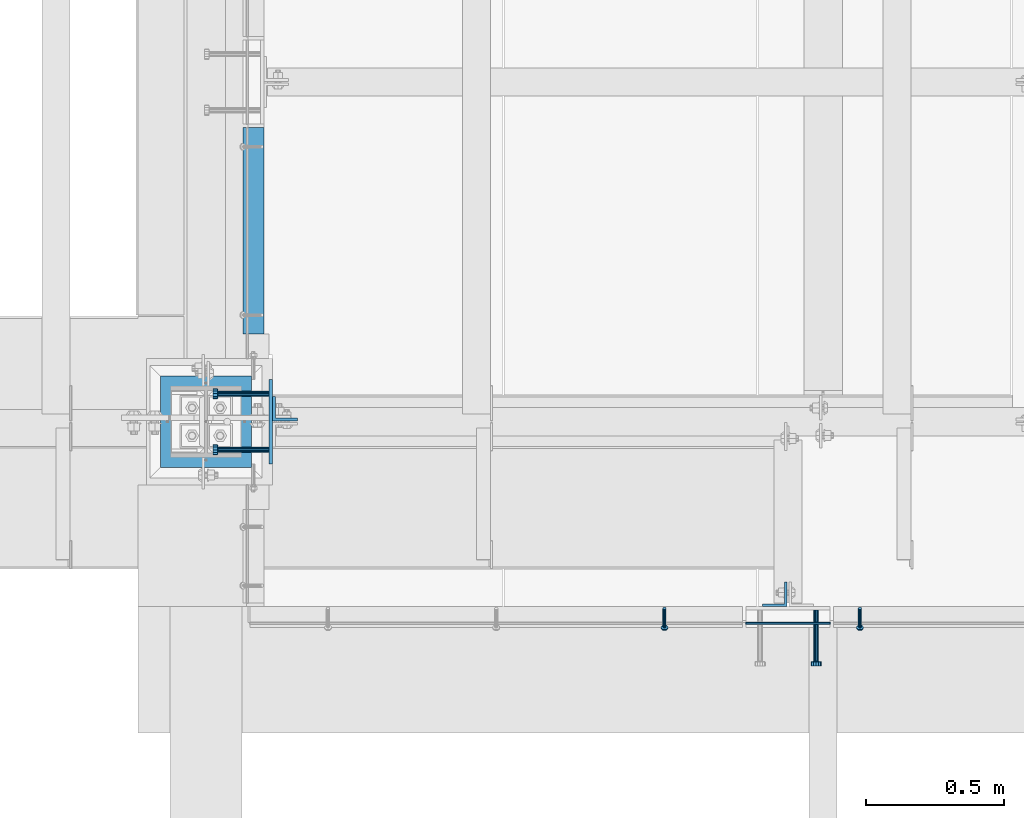
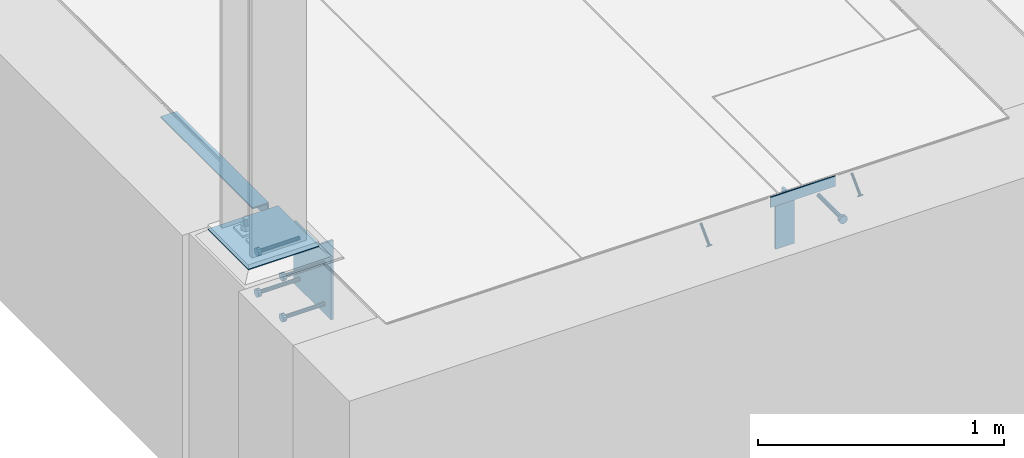
# One storey, part 2045 of 3843: 11 beams, 2 members, 8 elements without a shape of their own.
"""IFC2X3 building model written with IfcOpenShell, lengths in millimetres."""

from ifc_helpers import new_model, si_unit, frame, origin_with_axes, place, context, subcontext, project, spatial, faceted_brep, material, type_object, element, aggregate, save


model = new_model("IFC2X3")

# Units and contexts
model_context = context("Model", 3, precision=1e-05, world=origin_with_axes())
body_context = subcontext(model_context, "Body", "Model", "MODEL_VIEW")
ifc_project = project(units=[si_unit("LENGTHUNIT", "METRE", prefix="MILLI"), si_unit("AREAUNIT", "SQUARE_METRE"), si_unit("VOLUMEUNIT", "CUBIC_METRE"), si_unit("MASSUNIT", "GRAM", prefix="KILO"), si_unit("TIMEUNIT", "SECOND"), si_unit("PLANEANGLEUNIT", "RADIAN"), si_unit("SOLIDANGLEUNIT", "STERADIAN"), si_unit("THERMODYNAMICTEMPERATUREUNIT", "DEGREE_CELSIUS"), si_unit("LUMINOUSINTENSITYUNIT", "LUMEN")], contexts=[model_context])

# Site, building, storey
site_placement = place(None, origin_with_axes())
site = spatial("IfcSite", under=ifc_project, at=site_placement, CompositionType="ELEMENT")
building_placement = place(site_placement, origin_with_axes())
building = spatial("IfcBuilding", under=site, at=building_placement, Name="Undefined", CompositionType="ELEMENT")
storey_placement = place(building_placement, origin_with_axes())
storey = spatial("IfcBuildingStorey", under=building, at=storey_placement, Name="Undefined", CompositionType="ELEMENT", Elevation=0.0)

# Assembly, beam
assembly_1_placement = place(storey_placement, origin_with_axes())
assembly_1 = element("IfcElementAssembly", 1, at=assembly_1_placement, inside=storey, Name="EMBED PLATE", AssemblyPlace="NOTDEFINED", PredefinedType="RIGID_FRAME")
ifc_material_1 = material(Name="STEEL/A36")
beam_type_1 = type_object("IfcBeamType", PredefinedType="NOTDEFINED")
beam_1_placement = place(assembly_1_placement, frame((58191.4, 14268.45, 30454.6), z_axis=(0.0, 0.0, 1.0), x_axis=(-1.0, 0.0, 0.0)))
beam_1 = element("IfcBeam", 2, at=beam_1_placement, type_object=beam_type_1, material=ifc_material_1, Name="PLATE", context=body_context, shape_type="Brep", body=[
    faceted_brep([(0.0, 3.17499999999927, -25.4000000000015), (0.0, 3.17499999999927, 25.4000000000015), (304.800000000003, 3.17500000000291, 25.4000000000015), (304.800000000003, 3.17500000000291, -25.4000000000015), (0.0, -3.17499999999927, 25.4000000000015), (304.800000000003, -3.17500000000291, 25.4000000000015), (0.0, -3.17499999999927, -25.4000000000015), (304.800000000003, -3.17500000000291, -25.4000000000015)], [[[0, 1, 2, 3]], [[1, 4, 5, 2]], [[4, 6, 7, 5]], [[6, 0, 3, 7]], [[5, 7, 3, 2]], [[6, 4, 1, 0]]]),
])

# Assembly, member
assembly_2_placement = place(storey_placement, origin_with_axes())
assembly_2 = element("IfcElementAssembly", 3, at=assembly_2_placement, inside=storey, Name="ANGLE", AssemblyPlace="NOTDEFINED", PredefinedType="RIGID_FRAME")
ifc_material_2 = material(Name="STEEL/A108")
member_type = type_object("IfcMemberType", PredefinedType="NOTDEFINED")
member_1_placement = place(assembly_2_placement, frame((58299.3500082383, 14322.4244471697, 30422.8500024177), z_axis=(1.0, 0.0, 0.0), x_axis=(0.0, -0.707106781186548, -0.707106781186548)))
member_1 = element("IfcMember", 4, at=member_1_placement, type_object=member_type, material=ifc_material_2, Name="HEADED STUD ANCHOR", context=body_context, shape_type="Brep", body=[
    faceted_brep([(7.27595761418343e-12, -3.18000006675175, 5.5), (0.0, -5.49999999998363, 3.1800000667572), (94.4879985803855, -5.50000000011278, 3.1800000667572), (94.4879985803782, -3.18000006687362, 5.5), (0.0, -6.3499999046162, 0.0), (94.4879985803855, -6.34999990474535, 0.0), (0.0, -5.49999999998363, -3.1800000667572), (94.4879985803855, -5.50000000011278, -3.1800000667572), (7.27595761418343e-12, -3.18000006675175, -5.5), (94.4879985803782, -3.18000006687362, -5.5), (7.27595761418343e-12, -1.81898940354586e-12, -6.34999990463257), (94.4879985803782, -1.20053300634027e-10, -6.34999990463257), (0.0, 3.18000006675175, -5.5), (94.4879985803709, 3.18000006663351, -5.5), (7.27595761418343e-12, 5.49999999998363, -3.1800000667572), (94.4879985803709, 5.49999999987267, -3.1800000667572), (7.27595761418343e-12, 6.3499999046162, 0.0), (94.4879985803673, 6.34999990450706, 0.0), (7.27595761418343e-12, 5.49999999998363, 3.1800000667572), (94.4879985803709, 5.49999999987267, 3.1800000667572), (0.0, 3.18000006675175, 5.5), (94.4879985803709, 3.18000006663351, 5.5), (7.27595761418343e-12, -1.81898940354586e-12, 6.34999990463257), (94.4879985803782, -1.20053300634027e-10, 6.34999990463257), (96.5199985498621, -10.9899997712273, 6.34999990463257), (96.5199985498548, -6.34000015270249, 10.9899997711182), (96.5199985498621, -12.6999998093743, 0.0), (96.5199985498621, -10.9899997712273, -6.34999990463257), (96.5199985498548, -6.34000015270249, -10.9899997711182), (96.5199985498475, -1.21872290037572e-10, -12.6899995803833), (96.5199985498402, 6.34000015245874, -10.9899997711182), (96.519998549833, 10.9899997709817, -6.34999990463257), (96.519998549833, 12.6999998091305, 0.0), (96.519998549833, 10.9899997709817, 6.34999990463257), (96.5199985498402, 6.34000015245874, 10.9899997711182), (96.5199985498475, -1.21872290037572e-10, 12.6899995803833), (101.599998473539, -10.9899997712328, 6.34999990463257), (101.599998473532, -6.34000015270976, 10.9899997711182), (101.599998473539, -12.6999998093797, 0.0), (101.599998473539, -10.9899997712328, -6.34999990463257), (101.599998473532, -6.34000015270976, -10.9899997711182), (101.599998473524, -1.29148247651756e-10, -12.6899995803833), (101.599998473517, 6.34000015245329, -10.9899997711182), (101.59999847351, 10.9899997709763, -6.34999990463257), (101.599998473503, 12.6999998091196, 0.0), (101.59999847351, 10.9899997709763, 6.34999990463257), (101.599998473517, 6.34000015245329, 10.9899997711182), (101.599998473524, -1.29148247651756e-10, 12.6899995803833)], [[[0, 1, 2, 3]], [[1, 4, 5, 2]], [[4, 6, 7, 5]], [[6, 8, 9, 7]], [[8, 10, 11, 9]], [[10, 12, 13, 11]], [[12, 14, 15, 13]], [[14, 16, 17, 15]], [[16, 18, 19, 17]], [[18, 20, 21, 19]], [[20, 22, 23, 21]], [[22, 0, 3, 23]], [[22, 20, 18, 16, 14, 12, 10, 8, 6, 4, 1, 0]], [[3, 2, 24, 25]], [[2, 5, 26, 24]], [[5, 7, 27, 26]], [[7, 9, 28, 27]], [[9, 11, 29, 28]], [[11, 13, 30, 29]], [[13, 15, 31, 30]], [[15, 17, 32, 31]], [[17, 19, 33, 32]], [[19, 21, 34, 33]], [[21, 23, 35, 34]], [[23, 3, 25, 35]], [[25, 24, 36, 37]], [[24, 26, 38, 36]], [[26, 27, 39, 38]], [[27, 28, 40, 39]], [[28, 29, 41, 40]], [[29, 30, 42, 41]], [[30, 31, 43, 42]], [[31, 32, 44, 43]], [[32, 33, 45, 44]], [[33, 34, 46, 45]], [[34, 35, 47, 46]], [[35, 25, 37, 47]], [[38, 39, 40, 41, 42, 43, 44, 45, 46, 47, 37, 36]]]),
])
aggregate(assembly_2, [member_1])

assembly_3_placement = place(storey_placement, origin_with_axes())
assembly_3 = element("IfcElementAssembly", 5, at=assembly_3_placement, inside=storey, Name="ANGLE", AssemblyPlace="NOTDEFINED", PredefinedType="RIGID_FRAME")
member_2_placement = place(assembly_3_placement, frame((57591.324996253, 14322.4243726418, 30422.8500024177), z_axis=(1.0, 0.0, 0.0), x_axis=(0.0, -0.707106781186548, -0.707106781186548)))
member_2 = element("IfcMember", 6, at=member_2_placement, type_object=member_type, material=ifc_material_2, Name="HEADED STUD ANCHOR", context=body_context, shape_type="Brep", body=[
    faceted_brep([(7.27595761418343e-12, -3.18000006675175, 5.5), (0.0, -5.49999999998363, 3.1800000667572), (94.4879985803855, -5.50000000011278, 3.1800000667572), (94.4879985803782, -3.18000006687362, 5.5), (0.0, -6.3499999046162, 0.0), (94.4879985803855, -6.34999990474535, 0.0), (0.0, -5.49999999998363, -3.1800000667572), (94.4879985803855, -5.50000000011278, -3.1800000667572), (7.27595761418343e-12, -3.18000006675175, -5.5), (94.4879985803782, -3.18000006687362, -5.5), (7.27595761418343e-12, -1.81898940354586e-12, -6.34999990463257), (94.4879985803782, -1.20053300634027e-10, -6.34999990463257), (0.0, 3.18000006675175, -5.5), (94.4879985803709, 3.18000006663351, -5.5), (7.27595761418343e-12, 5.49999999998363, -3.1800000667572), (94.4879985803709, 5.49999999987267, -3.1800000667572), (7.27595761418343e-12, 6.3499999046162, 0.0), (94.4879985803673, 6.34999990450706, 0.0), (7.27595761418343e-12, 5.49999999998363, 3.1800000667572), (94.4879985803709, 5.49999999987267, 3.1800000667572), (0.0, 3.18000006675175, 5.5), (94.4879985803709, 3.18000006663351, 5.5), (7.27595761418343e-12, -1.81898940354586e-12, 6.34999990463257), (94.4879985803782, -1.20053300634027e-10, 6.34999990463257), (96.5199985498621, -10.9899997712273, 6.34999990463257), (96.5199985498548, -6.34000015270249, 10.9899997711182), (96.5199985498621, -12.6999998093743, 0.0), (96.5199985498621, -10.9899997712273, -6.34999990463257), (96.5199985498548, -6.34000015270249, -10.9899997711182), (96.5199985498475, -1.21872290037572e-10, -12.6899995803833), (96.5199985498402, 6.34000015245874, -10.9899997711182), (96.519998549833, 10.9899997709817, -6.34999990463257), (96.519998549833, 12.6999998091305, 0.0), (96.519998549833, 10.9899997709817, 6.34999990463257), (96.5199985498402, 6.34000015245874, 10.9899997711182), (96.5199985498475, -1.21872290037572e-10, 12.6899995803833), (101.599998473539, -10.9899997712328, 6.34999990463257), (101.599998473532, -6.34000015270976, 10.9899997711182), (101.599998473539, -12.6999998093797, 0.0), (101.599998473539, -10.9899997712328, -6.34999990463257), (101.599998473532, -6.34000015270976, -10.9899997711182), (101.599998473524, -1.29148247651756e-10, -12.6899995803833), (101.599998473517, 6.34000015245329, -10.9899997711182), (101.59999847351, 10.9899997709763, -6.34999990463257), (101.599998473503, 12.6999998091196, 0.0), (101.59999847351, 10.9899997709763, 6.34999990463257), (101.599998473517, 6.34000015245329, 10.9899997711182), (101.599998473524, -1.29148247651756e-10, 12.6899995803833)], [[[0, 1, 2, 3]], [[1, 4, 5, 2]], [[4, 6, 7, 5]], [[6, 8, 9, 7]], [[8, 10, 11, 9]], [[10, 12, 13, 11]], [[12, 14, 15, 13]], [[14, 16, 17, 15]], [[16, 18, 19, 17]], [[18, 20, 21, 19]], [[20, 22, 23, 21]], [[22, 0, 3, 23]], [[22, 20, 18, 16, 14, 12, 10, 8, 6, 4, 1, 0]], [[3, 2, 24, 25]], [[2, 5, 26, 24]], [[5, 7, 27, 26]], [[7, 9, 28, 27]], [[9, 11, 29, 28]], [[11, 13, 30, 29]], [[13, 15, 31, 30]], [[15, 17, 32, 31]], [[17, 19, 33, 32]], [[19, 21, 34, 33]], [[21, 23, 35, 34]], [[23, 3, 25, 35]], [[25, 24, 36, 37]], [[24, 26, 38, 36]], [[26, 27, 39, 38]], [[27, 28, 40, 39]], [[28, 29, 41, 40]], [[29, 30, 42, 41]], [[30, 31, 43, 42]], [[31, 32, 44, 43]], [[32, 33, 45, 44]], [[33, 34, 46, 45]], [[34, 35, 47, 46]], [[35, 25, 37, 47]], [[38, 39, 40, 41, 42, 43, 44, 45, 46, 47, 37, 36]]]),
])
aggregate(assembly_3, [member_2])

# Assembly, beam
assembly_4_placement = place(storey_placement, origin_with_axes())
assembly_4 = element("IfcElementAssembly", 7, at=assembly_4_placement, inside=storey, Name="EMBED PLATE", AssemblyPlace="NOTDEFINED", PredefinedType="RIGID_FRAME")
beam_type_2 = type_object("IfcBeamType", PredefinedType="NOTDEFINED")
beam_2_placement = place(assembly_4_placement, frame((56165.75, 14998.7, 30429.2), z_axis=(0.0, 1.0, 0.0), x_axis=(0.0, 0.0, -1.0)))
beam_2 = element("IfcBeam", 8, at=beam_2_placement, type_object=beam_type_2, material=ifc_material_1, Name="EMBED PLATE", context=body_context, shape_type="Brep", body=[
    faceted_brep([(-1.0550138540566e-10, 6.34999999999854, -152.400000000664), (1.0550138540566e-10, 6.34999999999854, 152.400000000656), (304.799999999999, 6.34999999999854, 152.400000000001), (304.799999999999, 6.34999999999854, -152.400000000001), (1.0550138540566e-10, -6.34999999999854, 152.400000000656), (304.799999999999, -6.34999999999854, 152.400000000001), (-1.0550138540566e-10, -6.34999999999854, -152.400000000664), (304.799999999999, -6.34999999999854, -152.400000000001)], [[[0, 1, 2, 3]], [[1, 4, 5, 2]], [[4, 6, 7, 5]], [[6, 0, 3, 7]], [[5, 7, 3, 2]], [[6, 4, 1, 0]]]),
])

assembly_5_placement = place(storey_placement, origin_with_axes())
assembly_5 = element("IfcElementAssembly", 9, at=assembly_5_placement, inside=storey, Name="ANGLE", AssemblyPlace="NOTDEFINED", PredefinedType="RIGID_FRAME")
beam_type_3 = type_object("IfcBeamType", Name="L3X3X1/4", PredefinedType="NOTDEFINED")
beam_3_placement = place(assembly_5_placement, frame((56102.2499885878, 15316.2000002665, 30391.1000045777), z_axis=(0.0, 0.0, -1.0), x_axis=(0.0, 1.0, 0.0)))
beam_3 = element("IfcBeam", 10, at=beam_3_placement, type_object=beam_type_3, material=ifc_material_1, Name="ANGLE", ObjectType="L3X3X1/4", context=body_context, shape_type="Brep", body=[
    faceted_brep([(0.0, 38.0999999999985, -38.0999999999985), (0.0, 38.0999999999985, 38.0999999999985), (747.71198334926, 38.0999999996129, 38.0999999999985), (747.71198334926, 38.0999999996129, -38.0999999999985), (0.0, 31.75, 38.0999999999985), (747.711983349258, 31.7499999996144, 38.0999999999985), (0.0, 31.75, -31.75), (747.711983349258, 31.7499999996144, -31.75), (0.0, -38.0999999999985, -31.75), (747.711983349222, -38.1000000003842, -31.75), (0.0, -38.0999999999985, -38.0999999999985), (747.711983349222, -38.1000000003842, -38.0999999999985)], [[[0, 1, 2, 3]], [[1, 4, 5, 2]], [[4, 6, 7, 5]], [[6, 8, 9, 7]], [[8, 10, 11, 9]], [[10, 0, 3, 11]], [[5, 7, 9, 11, 3, 2]], [[10, 8, 6, 4, 1, 0]]]),
])
aggregate(assembly_5, [beam_3])

assembly_6_placement = place(storey_placement, origin_with_axes())
assembly_6 = element("IfcElementAssembly", 11, at=assembly_6_placement, inside=storey, Name="BEAM", AssemblyPlace="NOTDEFINED", PredefinedType="RIGID_FRAME")
beam_type_4 = type_object("IfcBeamType", Name="L3-1/2X3-1/2X3/8", PredefinedType="NOTDEFINED")
beam_4_placement = place(assembly_6_placement, frame((56216.55, 15046.325, 30391.1), z_axis=(0.0, 1.0, 0.0), x_axis=(0.0, 0.0, -1.0)))
beam_4 = element("IfcBeam", 12, at=beam_4_placement, type_object=beam_type_4, material=ifc_material_1, Name="ANGLE", ObjectType="L3-1/2X3-1/2X3/8", context=body_context, shape_type="Brep", body=[
    faceted_brep([(-3.63797880709171e-12, 44.4499999999971, -44.4500000000007), (-3.63797880709171e-12, 44.4499999999971, 44.4500000000007), (228.600000000006, 44.4499999999971, 44.4500000000007), (228.600000000006, 44.4499999999971, -44.4500000000007), (0.0, 34.9250000000029, 44.4500000000007), (228.600000000006, 34.9250000000029, 44.4500000000007), (0.0, 34.9250000000029, -34.9250000000029), (228.600000000006, 34.9250000000029, -34.9249999999993), (0.0, -44.4499999999971, -34.9249999999993), (228.600000000006, -44.4499999999971, -34.9249999999993), (3.63797880709171e-12, -44.4499999999971, -44.4500000000007), (228.600000000006, -44.4499999999971, -44.4500000000007)], [[[0, 1, 2, 3]], [[1, 4, 5, 2]], [[4, 6, 7, 5]], [[6, 8, 9, 7]], [[8, 10, 11, 9]], [[10, 0, 3, 11]], [[5, 7, 9, 11, 3, 2]], [[10, 8, 6, 4, 1, 0]]]),
])
aggregate(assembly_6, [beam_4])

assembly_7_placement = place(storey_placement, origin_with_axes())
assembly_7 = element("IfcElementAssembly", 13, at=assembly_7_placement, inside=storey, Name="BEAM", AssemblyPlace="NOTDEFINED", PredefinedType="RIGID_FRAME")
beam_5_placement = place(assembly_7_placement, frame((57991.375, 14373.225, 30391.1), z_axis=(-1.0, 0.0, 0.0), x_axis=(0.0, 0.0, -1.0)))
beam_5 = element("IfcBeam", 14, at=beam_5_placement, type_object=beam_type_4, material=ifc_material_1, Name="ANGLE", ObjectType="L3-1/2X3-1/2X3/8", context=body_context, shape_type="Brep", body=[
    faceted_brep([(-3.63797880709171e-12, 44.4499999999971, -44.4500000000007), (-3.63797880709171e-12, 44.4499999999971, 44.4500000000007), (228.600000000006, 44.4499999999971, 44.4500000000007), (228.600000000006, 44.4499999999971, -44.4500000000007), (0.0, 34.9250000000029, 44.4500000000007), (228.600000000006, 34.9250000000029, 44.4500000000007), (0.0, 34.9250000000029, -34.9250000000029), (228.600000000006, 34.9250000000029, -34.9249999999993), (0.0, -44.4499999999971, -34.9249999999993), (228.600000000006, -44.4499999999971, -34.9249999999993), (3.63797880709171e-12, -44.4499999999971, -44.4500000000007), (228.600000000006, -44.4499999999971, -44.4500000000007)], [[[0, 1, 2, 3]], [[1, 4, 5, 2]], [[4, 6, 7, 5]], [[6, 8, 9, 7]], [[8, 10, 11, 9]], [[10, 0, 3, 11]], [[5, 7, 9, 11, 3, 2]], [[10, 8, 6, 4, 1, 0]]]),
])
aggregate(assembly_7, [beam_5])

# Beam
beam_type_5 = type_object("IfcBeamType", PredefinedType="NOTDEFINED")
beam_6_placement = place(assembly_4_placement, frame((56159.4, 14897.1, 30378.4), z_axis=(0.0, -1.0, 0.0), x_axis=(-1.0, 0.0, 0.0)))
beam_6 = element("IfcBeam", 15, at=beam_6_placement, type_object=beam_type_5, material=ifc_material_2, Name="HEADED STUD ANCHOR", context=body_context, shape_type="Brep", body=[
    faceted_brep([(0.0, -9.52000045776367, 0.0), (0.0, -8.25, -4.76000022888184), (184.912000000004, -8.25, -4.76000022888184), (184.912000000004, -9.52000045776367, 0.0), (0.0, -4.76000022888184, -8.25), (184.912000000004, -4.76000022888184, -8.25), (0.0, 0.0, -9.52000045776367), (184.912000000004, 0.0, -9.52000045776367), (0.0, 4.76000022888184, -8.25), (184.912000000004, 4.76000022888184, -8.25), (0.0, 8.25, -4.76000022888184), (184.912000000004, 8.25, -4.76000022888184), (0.0, 9.52000045776367, 0.0), (184.912000000004, 9.52000045776367, 0.0), (0.0, 8.25, 4.76000022888184), (184.912000000004, 8.25, 4.76000022888184), (0.0, 4.76000022888184, 8.25), (184.912000000004, 4.76000022888184, 8.25), (0.0, 0.0, 9.52000045776367), (184.912000000004, 0.0, 9.52000045776367), (0.0, -4.76000022888184, 8.25), (184.912000000004, -4.76000022888184, 8.25), (0.0, -8.25, 4.76000022888184), (184.912000000004, -8.25, 4.76000022888184), (186.944000000003, -16.5, -9.52000045776367), (186.944000000003, -19.0499992370605, 0.0), (186.944000000003, -9.52000045776367, -16.5), (186.944000000003, 0.0, -19.0499992370605), (186.944000000003, 9.52000045776367, -16.5), (186.944000000003, 16.5, -9.52000045776367), (186.944000000003, 19.0499992370605, 0.0), (186.944000000003, 16.5, 9.52000045776367), (186.944000000003, 9.52000045776367, 16.5), (186.944000000003, 0.0, 19.0499992370605), (186.944000000003, -9.52000045776367, 16.5), (186.944000000003, -16.5, 9.52000045776367), (203.199999999997, -16.5, -9.52000045776367), (203.199999999997, -19.0499992370605, 0.0), (203.199999999997, -9.52000045776367, -16.5), (203.199999999997, 0.0, -19.0499992370605), (203.199999999997, 9.52000045776367, -16.5), (203.199999999997, 16.5, -9.52000045776367), (203.199999999997, 19.0499992370605, 0.0), (203.199999999997, 16.5, 9.52000045776367), (203.199999999997, 9.52000045776367, 16.5), (203.199999999997, 0.0, 19.0499992370605), (203.199999999997, -9.52000045776367, 16.5), (203.199999999997, -16.5, 9.52000045776367)], [[[0, 1, 2, 3]], [[1, 4, 5, 2]], [[4, 6, 7, 5]], [[6, 8, 9, 7]], [[8, 10, 11, 9]], [[10, 12, 13, 11]], [[12, 14, 15, 13]], [[14, 16, 17, 15]], [[16, 18, 19, 17]], [[18, 20, 21, 19]], [[20, 22, 23, 21]], [[22, 0, 3, 23]], [[22, 20, 18, 16, 14, 12, 10, 8, 6, 4, 1, 0]], [[3, 2, 24, 25]], [[2, 5, 26, 24]], [[5, 7, 27, 26]], [[7, 9, 28, 27]], [[9, 11, 29, 28]], [[11, 13, 30, 29]], [[13, 15, 31, 30]], [[15, 17, 32, 31]], [[17, 19, 33, 32]], [[19, 21, 34, 33]], [[21, 23, 35, 34]], [[23, 3, 25, 35]], [[25, 24, 36, 37]], [[24, 26, 38, 36]], [[26, 27, 39, 38]], [[27, 28, 40, 39]], [[28, 29, 41, 40]], [[29, 30, 42, 41]], [[30, 31, 43, 42]], [[31, 32, 44, 43]], [[32, 33, 45, 44]], [[33, 34, 46, 45]], [[34, 35, 47, 46]], [[35, 25, 37, 47]], [[38, 39, 40, 41, 42, 43, 44, 45, 46, 47, 37, 36]]]),
])

beam_7_placement = place(assembly_4_placement, frame((56159.4, 14897.1, 30175.2), z_axis=(0.0, -1.0, 0.0), x_axis=(-1.0, 0.0, 0.0)))
beam_7 = element("IfcBeam", 16, at=beam_7_placement, type_object=beam_type_5, material=ifc_material_2, Name="HEADED STUD ANCHOR", context=body_context, shape_type="Brep", body=[
    faceted_brep([(0.0, -9.52000045776367, 0.0), (0.0, -8.25, -4.76000022888184), (184.912000000004, -8.25, -4.76000022888184), (184.912000000004, -9.52000045776367, 0.0), (0.0, -4.76000022888184, -8.25), (184.912000000004, -4.76000022888184, -8.25), (0.0, 0.0, -9.52000045776367), (184.912000000004, 0.0, -9.52000045776367), (0.0, 4.76000022888184, -8.25), (184.912000000004, 4.76000022888184, -8.25), (0.0, 8.25, -4.76000022888184), (184.912000000004, 8.25, -4.76000022888184), (0.0, 9.52000045776367, 0.0), (184.912000000004, 9.52000045776367, 0.0), (0.0, 8.25, 4.76000022888184), (184.912000000004, 8.25, 4.76000022888184), (0.0, 4.76000022888184, 8.25), (184.912000000004, 4.76000022888184, 8.25), (0.0, 0.0, 9.52000045776367), (184.912000000004, 0.0, 9.52000045776367), (0.0, -4.76000022888184, 8.25), (184.912000000004, -4.76000022888184, 8.25), (0.0, -8.25, 4.76000022888184), (184.912000000004, -8.25, 4.76000022888184), (186.944000000003, -16.5, -9.52000045776367), (186.944000000003, -19.0499992370605, 0.0), (186.944000000003, -9.52000045776367, -16.5), (186.944000000003, 0.0, -19.0499992370605), (186.944000000003, 9.52000045776367, -16.5), (186.944000000003, 16.5, -9.52000045776367), (186.944000000003, 19.0499992370605, 0.0), (186.944000000003, 16.5, 9.52000045776367), (186.944000000003, 9.52000045776367, 16.5), (186.944000000003, 0.0, 19.0499992370605), (186.944000000003, -9.52000045776367, 16.5), (186.944000000003, -16.5, 9.52000045776367), (203.199999999997, -16.5, -9.52000045776367), (203.199999999997, -19.0499992370605, 0.0), (203.199999999997, -9.52000045776367, -16.5), (203.199999999997, 0.0, -19.0499992370605), (203.199999999997, 9.52000045776367, -16.5), (203.199999999997, 16.5, -9.52000045776367), (203.199999999997, 19.0499992370605, 0.0), (203.199999999997, 16.5, 9.52000045776367), (203.199999999997, 9.52000045776367, 16.5), (203.199999999997, 0.0, 19.0499992370605), (203.199999999997, -9.52000045776367, 16.5), (203.199999999997, -16.5, 9.52000045776367)], [[[0, 1, 2, 3]], [[1, 4, 5, 2]], [[4, 6, 7, 5]], [[6, 8, 9, 7]], [[8, 10, 11, 9]], [[10, 12, 13, 11]], [[12, 14, 15, 13]], [[14, 16, 17, 15]], [[16, 18, 19, 17]], [[18, 20, 21, 19]], [[20, 22, 23, 21]], [[22, 0, 3, 23]], [[22, 20, 18, 16, 14, 12, 10, 8, 6, 4, 1, 0]], [[3, 2, 24, 25]], [[2, 5, 26, 24]], [[5, 7, 27, 26]], [[7, 9, 28, 27]], [[9, 11, 29, 28]], [[11, 13, 30, 29]], [[13, 15, 31, 30]], [[15, 17, 32, 31]], [[17, 19, 33, 32]], [[19, 21, 34, 33]], [[21, 23, 35, 34]], [[23, 3, 25, 35]], [[25, 24, 36, 37]], [[24, 26, 38, 36]], [[26, 27, 39, 38]], [[27, 28, 40, 39]], [[28, 29, 41, 40]], [[29, 30, 42, 41]], [[30, 31, 43, 42]], [[31, 32, 44, 43]], [[32, 33, 45, 44]], [[33, 34, 46, 45]], [[34, 35, 47, 46]], [[35, 25, 37, 47]], [[38, 39, 40, 41, 42, 43, 44, 45, 46, 47, 37, 36]]]),
])

beam_8_placement = place(assembly_4_placement, frame((56159.4, 15100.3, 30378.4), z_axis=(0.0, -1.0, 0.0), x_axis=(-1.0, 0.0, 0.0)))
beam_8 = element("IfcBeam", 17, at=beam_8_placement, type_object=beam_type_5, material=ifc_material_2, Name="HEADED STUD ANCHOR", context=body_context, shape_type="Brep", body=[
    faceted_brep([(0.0, -9.52000045776367, 0.0), (0.0, -8.25, -4.76000022888184), (184.912000000004, -8.25, -4.76000022888184), (184.912000000004, -9.52000045776367, 0.0), (0.0, -4.76000022888184, -8.25), (184.912000000004, -4.76000022888184, -8.25), (0.0, 0.0, -9.52000045776367), (184.912000000004, 0.0, -9.52000045776367), (0.0, 4.76000022888184, -8.25), (184.912000000004, 4.76000022888184, -8.25), (0.0, 8.25, -4.76000022888184), (184.912000000004, 8.25, -4.76000022888184), (0.0, 9.52000045776367, 0.0), (184.912000000004, 9.52000045776367, 0.0), (0.0, 8.25, 4.76000022888184), (184.912000000004, 8.25, 4.76000022888184), (0.0, 4.76000022888184, 8.25), (184.912000000004, 4.76000022888184, 8.25), (0.0, 0.0, 9.52000045776367), (184.912000000004, 0.0, 9.52000045776367), (0.0, -4.76000022888184, 8.25), (184.912000000004, -4.76000022888184, 8.25), (0.0, -8.25, 4.76000022888184), (184.912000000004, -8.25, 4.76000022888184), (186.944000000003, -16.5, -9.52000045776367), (186.944000000003, -19.0499992370605, 0.0), (186.944000000003, -9.52000045776367, -16.5), (186.944000000003, 0.0, -19.0499992370605), (186.944000000003, 9.52000045776367, -16.5), (186.944000000003, 16.5, -9.52000045776367), (186.944000000003, 19.0499992370605, 0.0), (186.944000000003, 16.5, 9.52000045776367), (186.944000000003, 9.52000045776367, 16.5), (186.944000000003, 0.0, 19.0499992370605), (186.944000000003, -9.52000045776367, 16.5), (186.944000000003, -16.5, 9.52000045776367), (203.199999999997, -16.5, -9.52000045776367), (203.199999999997, -19.0499992370605, 0.0), (203.199999999997, -9.52000045776367, -16.5), (203.199999999997, 0.0, -19.0499992370605), (203.199999999997, 9.52000045776367, -16.5), (203.199999999997, 16.5, -9.52000045776367), (203.199999999997, 19.0499992370605, 0.0), (203.199999999997, 16.5, 9.52000045776367), (203.199999999997, 9.52000045776367, 16.5), (203.199999999997, 0.0, 19.0499992370605), (203.199999999997, -9.52000045776367, 16.5), (203.199999999997, -16.5, 9.52000045776367)], [[[0, 1, 2, 3]], [[1, 4, 5, 2]], [[4, 6, 7, 5]], [[6, 8, 9, 7]], [[8, 10, 11, 9]], [[10, 12, 13, 11]], [[12, 14, 15, 13]], [[14, 16, 17, 15]], [[16, 18, 19, 17]], [[18, 20, 21, 19]], [[20, 22, 23, 21]], [[22, 0, 3, 23]], [[22, 20, 18, 16, 14, 12, 10, 8, 6, 4, 1, 0]], [[3, 2, 24, 25]], [[2, 5, 26, 24]], [[5, 7, 27, 26]], [[7, 9, 28, 27]], [[9, 11, 29, 28]], [[11, 13, 30, 29]], [[13, 15, 31, 30]], [[15, 17, 32, 31]], [[17, 19, 33, 32]], [[19, 21, 34, 33]], [[21, 23, 35, 34]], [[23, 3, 25, 35]], [[25, 24, 36, 37]], [[24, 26, 38, 36]], [[26, 27, 39, 38]], [[27, 28, 40, 39]], [[28, 29, 41, 40]], [[29, 30, 42, 41]], [[30, 31, 43, 42]], [[31, 32, 44, 43]], [[32, 33, 45, 44]], [[33, 34, 46, 45]], [[34, 35, 47, 46]], [[35, 25, 37, 47]], [[38, 39, 40, 41, 42, 43, 44, 45, 46, 47, 37, 36]]]),
])

beam_9_placement = place(assembly_4_placement, frame((56159.4, 15100.3, 30175.2), z_axis=(0.0, -1.0, 0.0), x_axis=(-1.0, 0.0, 0.0)))
beam_9 = element("IfcBeam", 18, at=beam_9_placement, type_object=beam_type_5, material=ifc_material_2, Name="HEADED STUD ANCHOR", context=body_context, shape_type="Brep", body=[
    faceted_brep([(0.0, -9.52000045776367, 0.0), (0.0, -8.25, -4.76000022888184), (184.912000000004, -8.25, -4.76000022888184), (184.912000000004, -9.52000045776367, 0.0), (0.0, -4.76000022888184, -8.25), (184.912000000004, -4.76000022888184, -8.25), (0.0, 0.0, -9.52000045776367), (184.912000000004, 0.0, -9.52000045776367), (0.0, 4.76000022888184, -8.25), (184.912000000004, 4.76000022888184, -8.25), (0.0, 8.25, -4.76000022888184), (184.912000000004, 8.25, -4.76000022888184), (0.0, 9.52000045776367, 0.0), (184.912000000004, 9.52000045776367, 0.0), (0.0, 8.25, 4.76000022888184), (184.912000000004, 8.25, 4.76000022888184), (0.0, 4.76000022888184, 8.25), (184.912000000004, 4.76000022888184, 8.25), (0.0, 0.0, 9.52000045776367), (184.912000000004, 0.0, 9.52000045776367), (0.0, -4.76000022888184, 8.25), (184.912000000004, -4.76000022888184, 8.25), (0.0, -8.25, 4.76000022888184), (184.912000000004, -8.25, 4.76000022888184), (186.944000000003, -16.5, -9.52000045776367), (186.944000000003, -19.0499992370605, 0.0), (186.944000000003, -9.52000045776367, -16.5), (186.944000000003, 0.0, -19.0499992370605), (186.944000000003, 9.52000045776367, -16.5), (186.944000000003, 16.5, -9.52000045776367), (186.944000000003, 19.0499992370605, 0.0), (186.944000000003, 16.5, 9.52000045776367), (186.944000000003, 9.52000045776367, 16.5), (186.944000000003, 0.0, 19.0499992370605), (186.944000000003, -9.52000045776367, 16.5), (186.944000000003, -16.5, 9.52000045776367), (203.199999999997, -16.5, -9.52000045776367), (203.199999999997, -19.0499992370605, 0.0), (203.199999999997, -9.52000045776367, -16.5), (203.199999999997, 0.0, -19.0499992370605), (203.199999999997, 9.52000045776367, -16.5), (203.199999999997, 16.5, -9.52000045776367), (203.199999999997, 19.0499992370605, 0.0), (203.199999999997, 16.5, 9.52000045776367), (203.199999999997, 9.52000045776367, 16.5), (203.199999999997, 0.0, 19.0499992370605), (203.199999999997, -9.52000045776367, 16.5), (203.199999999997, -16.5, 9.52000045776367)], [[[0, 1, 2, 3]], [[1, 4, 5, 2]], [[4, 6, 7, 5]], [[6, 8, 9, 7]], [[8, 10, 11, 9]], [[10, 12, 13, 11]], [[12, 14, 15, 13]], [[14, 16, 17, 15]], [[16, 18, 19, 17]], [[18, 20, 21, 19]], [[20, 22, 23, 21]], [[22, 0, 3, 23]], [[22, 20, 18, 16, 14, 12, 10, 8, 6, 4, 1, 0]], [[3, 2, 24, 25]], [[2, 5, 26, 24]], [[5, 7, 27, 26]], [[7, 9, 28, 27]], [[9, 11, 29, 28]], [[11, 13, 30, 29]], [[13, 15, 31, 30]], [[15, 17, 32, 31]], [[17, 19, 33, 32]], [[19, 21, 34, 33]], [[21, 23, 35, 34]], [[23, 3, 25, 35]], [[25, 24, 36, 37]], [[24, 26, 38, 36]], [[26, 27, 39, 38]], [[27, 28, 40, 39]], [[28, 29, 41, 40]], [[29, 30, 42, 41]], [[30, 31, 43, 42]], [[31, 32, 44, 43]], [[32, 33, 45, 44]], [[33, 34, 46, 45]], [[34, 35, 47, 46]], [[35, 25, 37, 47]], [[38, 39, 40, 41, 42, 43, 44, 45, 46, 47, 37, 36]]]),
])

aggregate(assembly_4, [beam_6, beam_7, beam_8, beam_9, beam_2])

beam_10_placement = place(assembly_1_placement, frame((58140.6, 14316.075, 30372.05), z_axis=(1.0, 0.0, 0.0), x_axis=(0.0, -1.0, 0.0)))
beam_10 = element("IfcBeam", 19, at=beam_10_placement, type_object=beam_type_5, material=ifc_material_2, Name="HEADED STUD ANCHOR", context=body_context, shape_type="Brep", body=[
    faceted_brep([(0.0, -9.52000045776367, 0.0), (0.0, -8.25, -4.76000022888184), (184.912000000004, -8.25, -4.76000022888184), (184.912000000004, -9.52000045776367, 0.0), (0.0, -4.76000022888184, -8.25), (184.912000000004, -4.76000022888184, -8.25), (0.0, 0.0, -9.52000045776367), (184.912000000004, 0.0, -9.52000045776367), (0.0, 4.76000022888184, -8.25), (184.912000000004, 4.76000022888184, -8.25), (0.0, 8.25, -4.76000022888184), (184.912000000004, 8.25, -4.76000022888184), (0.0, 9.52000045776367, 0.0), (184.912000000004, 9.52000045776367, 0.0), (0.0, 8.25, 4.76000022888184), (184.912000000004, 8.25, 4.76000022888184), (0.0, 4.76000022888184, 8.25), (184.912000000004, 4.76000022888184, 8.25), (0.0, 0.0, 9.52000045776367), (184.912000000004, 0.0, 9.52000045776367), (0.0, -4.76000022888184, 8.25), (184.912000000004, -4.76000022888184, 8.25), (0.0, -8.25, 4.76000022888184), (184.912000000004, -8.25, 4.76000022888184), (186.944000000003, -16.5, -9.52000045776367), (186.944000000003, -19.0499992370605, 0.0), (186.944000000003, -9.52000045776367, -16.5), (186.944000000003, 0.0, -19.0499992370605), (186.944000000003, 9.52000045776367, -16.5), (186.944000000003, 16.5, -9.52000045776367), (186.944000000003, 19.0499992370605, 0.0), (186.944000000003, 16.5, 9.52000045776367), (186.944000000003, 9.52000045776367, 16.5), (186.944000000003, 0.0, 19.0499992370605), (186.944000000003, -9.52000045776367, 16.5), (186.944000000003, -16.5, 9.52000045776367), (203.199999999997, -16.5, -9.52000045776367), (203.199999999997, -19.0499992370605, 0.0), (203.199999999997, -9.52000045776367, -16.5), (203.199999999997, 0.0, -19.0499992370605), (203.199999999997, 9.52000045776367, -16.5), (203.199999999997, 16.5, -9.52000045776367), (203.199999999997, 19.0499992370605, 0.0), (203.199999999997, 16.5, 9.52000045776367), (203.199999999997, 9.52000045776367, 16.5), (203.199999999997, 0.0, 19.0499992370605), (203.199999999997, -9.52000045776367, 16.5), (203.199999999997, -16.5, 9.52000045776367)], [[[0, 1, 2, 3]], [[1, 4, 5, 2]], [[4, 6, 7, 5]], [[6, 8, 9, 7]], [[8, 10, 11, 9]], [[10, 12, 13, 11]], [[12, 14, 15, 13]], [[14, 16, 17, 15]], [[16, 18, 19, 17]], [[18, 20, 21, 19]], [[20, 22, 23, 21]], [[22, 0, 3, 23]], [[22, 20, 18, 16, 14, 12, 10, 8, 6, 4, 1, 0]], [[3, 2, 24, 25]], [[2, 5, 26, 24]], [[5, 7, 27, 26]], [[7, 9, 28, 27]], [[9, 11, 29, 28]], [[11, 13, 30, 29]], [[13, 15, 31, 30]], [[15, 17, 32, 31]], [[17, 19, 33, 32]], [[19, 21, 34, 33]], [[21, 23, 35, 34]], [[23, 3, 25, 35]], [[25, 24, 36, 37]], [[24, 26, 38, 36]], [[26, 27, 39, 38]], [[27, 28, 40, 39]], [[28, 29, 41, 40]], [[29, 30, 42, 41]], [[30, 31, 43, 42]], [[31, 32, 44, 43]], [[32, 33, 45, 44]], [[33, 34, 46, 45]], [[34, 35, 47, 46]], [[35, 25, 37, 47]], [[38, 39, 40, 41, 42, 43, 44, 45, 46, 47, 37, 36]]]),
])

aggregate(assembly_1, [beam_1, beam_10])

# Assembly, beam
assembly_8_placement = place(storey_placement, origin_with_axes())
assembly_8 = element("IfcElementAssembly", 20, at=assembly_8_placement, inside=storey, Name="TEMPLATE", AssemblyPlace="NOTDEFINED", PredefinedType="RIGID_FRAME")
ifc_material_3 = material(Name="STEEL/A572-50")
beam_type_6 = type_object("IfcBeamType", PredefinedType="NOTDEFINED")
beam_11_placement = place(assembly_8_placement, frame((55930.8, 14833.6000007629, 30520.4815), z_axis=(-1.0, 0.0, 0.0), x_axis=(0.0, 1.0, 0.0)))
beam_11 = element("IfcBeam", 21, at=beam_11_placement, type_object=beam_type_6, material=ifc_material_3, Name="TEMPLATE", context=body_context, shape_type="Brep", body=[
    faceted_brep([(0.0, 2.38149999999951, -165.100000000006), (0.0, 2.38149999999951, 165.100000000006), (330.199996948242, 2.38149999999951, 165.100000000006), (330.199996948242, 2.38149999999951, -165.100000000006), (0.0, -2.38149999999951, 165.100000000006), (330.199996948242, -2.38149999999951, 165.100000000006), (0.0, -2.38149999999951, -165.100000000006), (330.199996948242, -2.38149999999951, -165.100000000006)], [[[0, 1, 2, 3]], [[1, 4, 5, 2]], [[4, 6, 7, 5]], [[6, 0, 3, 7]], [[5, 7, 3, 2]], [[6, 4, 1, 0]]]),
])
aggregate(assembly_8, [beam_11])

save(model, "model.ifc")
